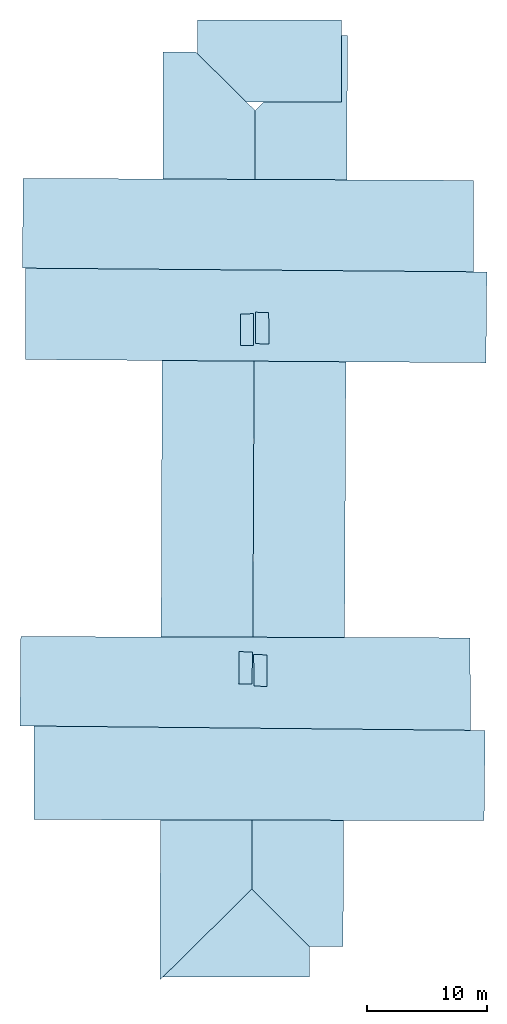
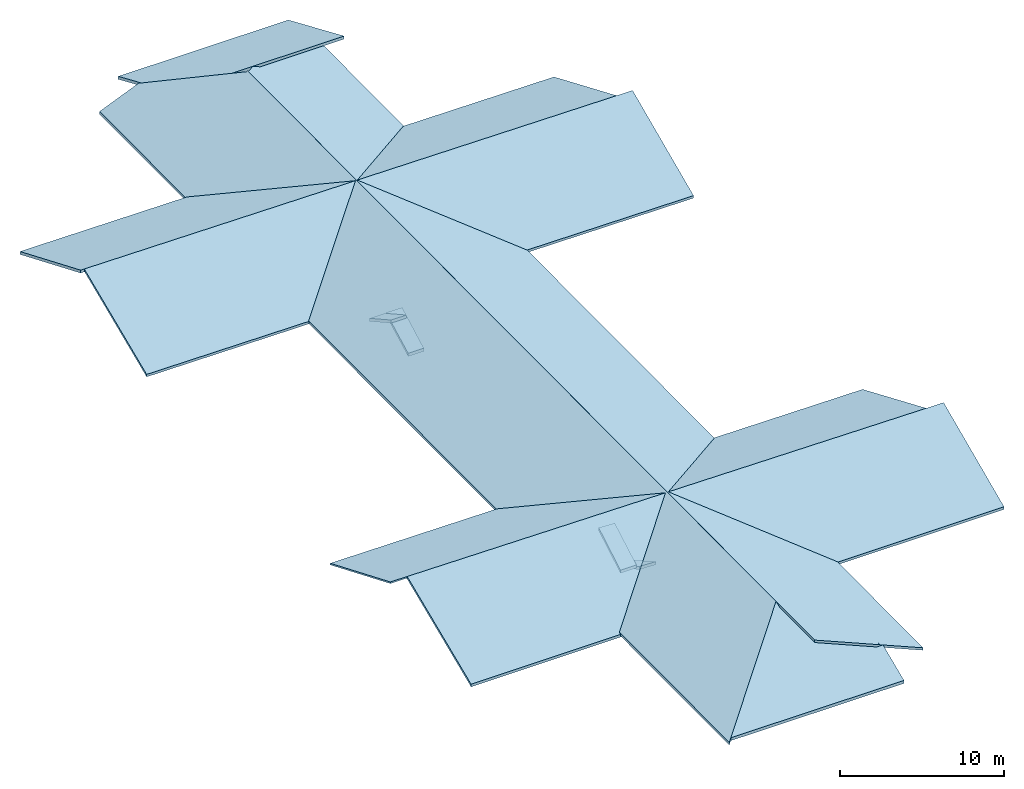
# One storey: 12 slabs, 1 element without a shape of its own.
"""IFC2X3 building model written with IfcOpenShell, lengths in metres."""

from ifc_helpers import new_model, entity, si_unit, converted_unit, derived_unit, direction, frame, origin, place, context, subcontext, project, spatial, polyline, outline, extrude, material, layer, layer_set, type_object, element, aggregate, save


model = new_model("IFC2X3")

# Units and contexts
model_context = context("Model", 3, precision=1e-05, world=origin(), true_north=direction((0.0, 1.0)))
body_context = subcontext(model_context, "Body", "Model", "MODEL_VIEW")
ifc_project = project(units=[si_unit("LENGTHUNIT", "METRE"), si_unit("AREAUNIT", "SQUARE_METRE"), si_unit("VOLUMEUNIT", "CUBIC_METRE"), converted_unit("PLANEANGLEUNIT", "DEGREE", entity("IfcRatioMeasure", 0.0174532925199433), si_unit("PLANEANGLEUNIT", "RADIAN"), dimensions=[0, 0, 0, 0, 0, 0, 0]), si_unit("MASSUNIT", "GRAM", prefix="KILO"), derived_unit("MASSDENSITYUNIT", [(si_unit("MASSUNIT", "GRAM", prefix="KILO"), 1), (si_unit("LENGTHUNIT", "METRE"), -3)]), derived_unit("MOMENTOFINERTIAUNIT", [(si_unit("LENGTHUNIT", "METRE"), 4)]), si_unit("TIMEUNIT", "SECOND"), si_unit("FREQUENCYUNIT", "HERTZ"), si_unit("THERMODYNAMICTEMPERATUREUNIT", "DEGREE_CELSIUS"), derived_unit("THERMALTRANSMITTANCEUNIT", [(si_unit("MASSUNIT", "GRAM", prefix="KILO"), 1), (si_unit("THERMODYNAMICTEMPERATUREUNIT", "KELVIN"), -1), (si_unit("TIMEUNIT", "SECOND"), -3)]), derived_unit("VOLUMETRICFLOWRATEUNIT", [(si_unit("LENGTHUNIT", "METRE"), 3), (si_unit("TIMEUNIT", "SECOND"), -1)]), si_unit("ELECTRICCURRENTUNIT", "AMPERE"), si_unit("ELECTRICVOLTAGEUNIT", "VOLT"), si_unit("POWERUNIT", "WATT"), si_unit("FORCEUNIT", "NEWTON", prefix="KILO"), si_unit("ILLUMINANCEUNIT", "LUX"), si_unit("LUMINOUSFLUXUNIT", "LUMEN"), si_unit("LUMINOUSINTENSITYUNIT", "CANDELA"), derived_unit("USERDEFINED", [(si_unit("MASSUNIT", "GRAM", prefix="KILO"), -1), (si_unit("LENGTHUNIT", "METRE"), -2), (si_unit("TIMEUNIT", "SECOND"), 3), (si_unit("LUMINOUSFLUXUNIT", "LUMEN"), 1)]), derived_unit("LINEARVELOCITYUNIT", [(si_unit("LENGTHUNIT", "METRE"), 1), (si_unit("TIMEUNIT", "SECOND"), -1)]), si_unit("PRESSUREUNIT", "PASCAL"), derived_unit("USERDEFINED", [(si_unit("LENGTHUNIT", "METRE"), -2), (si_unit("MASSUNIT", "GRAM", prefix="KILO"), 1), (si_unit("TIMEUNIT", "SECOND"), -2)]), derived_unit("LINEARFORCEUNIT", [(si_unit("MASSUNIT", "GRAM", prefix="KILO"), 1), (si_unit("LENGTHUNIT", "METRE"), 1), (si_unit("TIMEUNIT", "SECOND"), -2), (si_unit("LENGTHUNIT", "METRE"), -1)]), derived_unit("PLANARFORCEUNIT", [(si_unit("MASSUNIT", "GRAM", prefix="KILO"), 1), (si_unit("LENGTHUNIT", "METRE"), 1), (si_unit("TIMEUNIT", "SECOND"), -2), (si_unit("LENGTHUNIT", "METRE"), -2)])], contexts=[model_context])

# Site, building, storey
placement_1 = place(None, origin())
site = spatial("IfcSite", under=ifc_project, at=placement_1, CompositionType="ELEMENT")
building = spatial("IfcBuilding", under=site, at=placement_1, CompositionType="ELEMENT")
storey_placement = place(placement_1, frame((0.0, 0.0, 12.0740594863892)))
storey = spatial("IfcBuildingStorey", under=building, at=storey_placement, Name="Level 7", CompositionType="ELEMENT", Elevation=12.0740594863892)

# Roof, slabs
placement_2 = place(storey_placement, frame((7.39193296432495, 25.5369510650635, 0.0)))
roof = element("IfcRoof", 1, at=placement_2, inside=storey, Name="Roof", ObjectType="Roof", ShapeType="NOTDEFINED")
ifc_material = material(Name="Roof default")
ifc_layer_1 = layer(ifc_material, 0.217768470107194)
ifc_layer_set_1 = layer_set([ifc_layer_1], Name="Roof : 218mm")
slab_type_1 = type_object("IfcSlabType", Name="Roof : 218mm", PredefinedType="ROOF")
slab_1 = element("IfcSlab", 2, at=placement_2, type_object=slab_type_1, material=ifc_layer_set_1, Name="Roof : 218mm", ObjectType="Roof : 218mm", PredefinedType="ROOF", context=body_context, shape_type="SweptSolid", body=[
    extrude(outline(polyline([(-6.3857951637948, -3.58598383333965), (5.6142050412514, -3.58598383333965), (5.61420558800333, -0.525409985978629), (1.54317774123407, 3.84869225794582), (-6.385793206694, 3.84868539471213), (-6.3857951637948, -3.58598383333965)])), frame((-0.181047487258911, 49.685680770874, 7.41410465240479), z_axis=(-0.000154947056043607, 0.39563783301091, 0.918406598997329), x_axis=(-0.999999923308173, -0.000391642245912104, 0.0)), (0.0, -0.395637863352535, -0.918406598997329), 0.217768470107194),
])
ifc_layer_2 = layer(ifc_material, 0.119412025479108)
ifc_layer_set_2 = layer_set([ifc_layer_2], Name="Roof : 119mm")
slab_type_2 = type_object("IfcSlabType", Name="Roof : 119mm", PredefinedType="ROOF")
slab_2 = element("IfcSlab", 3, at=placement_2, type_object=slab_type_2, material=ifc_layer_set_2, Name="Roof : 119mm", ObjectType="Roof : 119mm", PredefinedType="ROOF", context=body_context, shape_type="SweptSolid", body=[
    extrude(outline(polyline([(-18.8288565602033, 4.11821929552242), (18.7692497860591, 4.11821929552242), (18.7800360802138, -3.97787922067479), (-18.7204293060697, -4.25855937037005), (-18.8288565602033, 4.11821929552242)])), frame((-1.80208086967468, -2.32204294204712, 7.59302234649658), z_axis=(0.00333846502212982, 0.389121835539899, 0.921180249330909), x_axis=(-0.999951782229567, 0.0098063456725786, -0.000518459702406836)), (0.000518459702406836, -0.389135811094586, -0.921180249330909), 0.119412025479108),
])
ifc_layer_3 = layer(ifc_material, 0.184715240861864)
ifc_layer_set_3 = layer_set([ifc_layer_3], Name="Roof : 185mm")
slab_type_3 = type_object("IfcSlabType", Name="Roof : 185mm", PredefinedType="ROOF")
slab_3 = element("IfcSlab", 4, at=placement_2, type_object=slab_type_3, material=ifc_layer_set_3, Name="Roof : 185mm", ObjectType="Roof : 185mm", PredefinedType="ROOF", context=body_context, shape_type="SweptSolid", body=[
    extrude(outline(polyline([(-19.2619894661813, 4.13158140423691), (19.2422873755232, 4.13158140423691), (19.2262536582179, -4.10914581566985), (-19.2065515675597, -4.15401699280397), (-19.2619894661813, 4.13158140423691)])), frame((-0.913518905639648, 28.3109664916992, 7.60502958297729), z_axis=(-0.00388801613831628, -0.391110430364562, 0.920335544565435), x_axis=(0.999966498948913, -0.00814996324829607, 0.000760972341273259)), (-0.000760972341273259, -0.39112901494269, -0.920335544565435), 0.184715240861864),
])
ifc_layer_4 = layer(ifc_material, 0.229266396797613)
ifc_layer_set_4 = layer_set([ifc_layer_4], Name="Roof : 229mm")
slab_type_4 = type_object("IfcSlabType", Name="Roof : 229mm", PredefinedType="ROOF")
slab_4 = element("IfcSlab", 5, at=placement_2, type_object=slab_type_4, material=ifc_layer_set_4, Name="Roof : 229mm", ObjectType="Roof : 229mm", PredefinedType="ROOF", context=body_context, shape_type="SweptSolid", body=[
    extrude(outline(polyline([(-1.51935959486812, 0.55650561620363), (1.54299250107226, 0.55650561620363), (1.53907285429364, -0.564201966580248), (-1.56270576049778, -0.548809265827012), (-1.51935959486812, 0.55650561620363)])), frame((-1.78134882450104, -1.09667873382568, 2.31131076812744), z_axis=(-0.0243790702688129, -0.488277848434215, 0.872347639224915), x_axis=(-0.00432981265470149, -0.87254717212928, -0.488510680672974)), (0.488510680672974, -0.019157737215033, -0.872347639224915), 0.229266396797613),
])
ifc_layer_5 = layer(ifc_material, 0.217144558305714)
ifc_layer_set_5 = layer_set([ifc_layer_5], Name="Roof : 217mm")
slab_type_5 = type_object("IfcSlabType", Name="Roof : 217mm", PredefinedType="ROOF")
slab_5 = element("IfcSlab", 6, at=placement_2, type_object=slab_type_5, material=ifc_layer_set_5, Name="Roof : 217mm", ObjectType="Roof : 217mm", PredefinedType="ROOF", context=body_context, shape_type="SweptSolid", body=[
    extrude(outline(polyline([(-18.8415429343464, 4.10588699379715), (18.7951549636456, 4.10588699379715), (18.8110532528547, -4.03387776003341), (-18.7646652821539, -4.17789622756088), (-18.8415429343464, 4.10588699379715)])), frame((-1.5740692615509, 35.9007530212402, 7.62140560150146), z_axis=(0.00247318675626255, 0.389447333185159, 0.921045415830423), x_axis=(-0.999966498488344, 0.00815001911061042, -0.000760979274747706)), (0.000760979274747706, -0.389454442630115, -0.921045415830423), 0.217144558305714),
])
ifc_layer_6 = layer(ifc_material, 0.195401984485415)
ifc_layer_set_6 = layer_set([ifc_layer_6], Name="Roof : 195mm")
slab_type_6 = type_object("IfcSlabType", Name="Roof : 195mm", PredefinedType="ROOF")
slab_6 = element("IfcSlab", 7, at=placement_2, type_object=slab_type_6, material=ifc_layer_set_6, Name="Roof : 195mm", ObjectType="Roof : 195mm", PredefinedType="ROOF", context=body_context, shape_type="SweptSolid", body=[
    extrude(outline(polyline([(-18.8351210278197, 4.16102427486376), (18.8032027729246, 4.16102427486376), (18.7923295407188, -4.00564113800127), (-18.7604112858236, -4.31640741172624), (-18.8351210278197, 4.16102427486376)])), frame((-0.627567291259766, -9.96059513092041, 7.57699155807495), z_axis=(-0.00429362844020268, -0.389117818894902, 0.921177989192801), x_axis=(0.999951781617494, -0.00980640790316349, 0.000518463148508191)), (-0.000518463148508191, -0.38914116133494, -0.921177989192801), 0.195401984485415),
])
ifc_layer_7 = layer(ifc_material, 0.195470123302789)
ifc_layer_set_7 = layer_set([ifc_layer_7], Name="Roof : 195mm")
slab_type_7 = type_object("IfcSlabType", Name="Roof : 195mm", PredefinedType="ROOF")
slab_7 = element("IfcSlab", 8, at=placement_2, type_object=slab_type_7, material=ifc_layer_set_7, Name="Roof : 195mm", ObjectType="Roof : 195mm", PredefinedType="ROOF", context=body_context, shape_type="SweptSolid", body=[
    extrude(outline(polyline([(-3.99167093085398, 30.4217228890451), (-1.02353694424075, 30.4217228890451), (4.37056998494758, 25.5809820882312), (4.46541899309278, -39.399775859742), (-3.82078110294563, -47.0246520065793), (-3.99167093085398, 30.4217228890451)])), frame((-5.15121760368347, 19.863486123085, 7.52554683685303), z_axis=(-0.389898208227366, 0.00141442962832144, 0.920856876289642), x_axis=(0.920839306976034, -0.0055469980373844, 0.389902810378011)), (-0.389902810378011, -0.000860302197111534, -0.920856876289642), 0.195470123302789),
])
ifc_layer_8 = layer(ifc_material, 0.229634747304557)
ifc_layer_set_8 = layer_set([ifc_layer_8], Name="Roof : 230mm")
slab_type_8 = type_object("IfcSlabType", Name="Roof : 230mm", PredefinedType="ROOF")
slab_8 = element("IfcSlab", 9, at=placement_2, type_object=slab_type_8, material=ifc_layer_set_8, Name="Roof : 230mm", ObjectType="Roof : 230mm", PredefinedType="ROOF", context=body_context, shape_type="SweptSolid", body=[
    extrude(outline(polyline([(-0.490639165654679, -1.50829935127792), (0.632500108357875, -1.50829935127792), (0.479044529665485, 1.52897332786262), (-0.620905472368681, 1.48762537469322), (-0.490639165654679, -1.50829935127792)])), frame((-0.543899655342102, -1.30667543411255, 0.751009702682495), z_axis=(0.0234513210202772, 0.490814669245308, 0.870948331415832), x_axis=(0.998808787386625, -0.0487918416151151, 0.000602022479292691)), (-0.000602022479292691, 0.49137423776136, -0.870948331415832), 0.229634747304557),
])
ifc_layer_9 = layer(ifc_material, 0.184661602017456)
ifc_layer_set_9 = layer_set([ifc_layer_9], Name="Roof : 185mm")
slab_type_9 = type_object("IfcSlabType", Name="Roof : 185mm", PredefinedType="ROOF")
slab_9 = element("IfcSlab", 10, at=placement_2, type_object=slab_type_9, material=ifc_layer_set_9, Name="Roof : 185mm", ObjectType="Roof : 185mm", PredefinedType="ROOF", context=body_context, shape_type="SweptSolid", body=[
    extrude(outline(polyline([(-22.9608196370454, -21.9356089009746), (-13.5910662224233, -21.9356089009746), (33.3484424058167, 29.6404066141122), (27.208864998759, 35.2136844924866), (-24.0054215451069, -20.9828733046497), (-22.9608196370454, -21.9356089009746)])), frame((3.24931411743164, 20.031014585495, 7.40465869903565), z_axis=(0.390495481927971, -0.00190379882303888, 0.920602875372374), x_axis=(-0.683703853162157, -0.670257912805579, 0.288623234499112)), (-0.288623234499112, 0.263034321268011, -0.920602875372374), 0.184661602017456),
])
ifc_layer_10 = layer(ifc_material, 0.228960941553307)
ifc_layer_set_10 = layer_set([ifc_layer_10], Name="Roof : 229mm")
slab_type_10 = type_object("IfcSlabType", Name="Roof : 229mm", PredefinedType="ROOF")
slab_10 = element("IfcSlab", 11, at=placement_2, type_object=slab_type_10, material=ifc_layer_set_10, Name="Roof : 229mm", ObjectType="Roof : 229mm", PredefinedType="ROOF", context=body_context, shape_type="SweptSolid", body=[
    extrude(outline(polyline([(-1.51863489812532, -0.555277141518082), (1.49173368752047, -0.555277141518082), (1.51045011871215, 0.544745421207774), (-1.48354890810731, 0.56580886182839), (-1.51863489812532, -0.555277141518082)])), frame((-0.398901343345642, 27.2704563140869, 0.74419116973877), z_axis=(-0.0129766594885699, -0.486630644253648, 0.873511432313165), x_axis=(0.0119012535715476, -0.873598106046444, -0.486502527511926)), (0.486502527511926, -0.0171278998449736, -0.873511432313165), 0.228960941553307),
])
ifc_layer_11 = layer(ifc_material, 0.228913058881483)
ifc_layer_set_11 = layer_set([ifc_layer_11], Name="Roof : 229mm")
slab_type_11 = type_object("IfcSlabType", Name="Roof : 229mm", PredefinedType="ROOF")
slab_11 = element("IfcSlab", 12, at=placement_2, type_object=slab_type_11, material=ifc_layer_set_11, Name="Roof : 229mm", ObjectType="Roof : 229mm", PredefinedType="ROOF", context=body_context, shape_type="SweptSolid", body=[
    extrude(outline(polyline([(-1.50555512599314, 0.550809919836056), (1.49504147633464, 0.550809919836056), (1.51305256774399, -0.549770718441966), (-1.50253891808549, -0.551849121230146), (-1.50555512599314, 0.550809919836056)])), frame((-1.67189478874207, 27.147928237915, 2.28672814369202), z_axis=(0.00964864493000085, 0.486379932754002, 0.873694148237944), x_axis=(-0.00265593163001865, 0.873744138280057, -0.486378583871059)), (0.486378583871059, -0.00972223879754161, -0.873694148237944), 0.228913058881483),
])
ifc_layer_12 = layer(ifc_material, 0.217474616773754)
ifc_layer_set_12 = layer_set([ifc_layer_12], Name="Roof : 217mm")
slab_type_12 = type_object("IfcSlabType", Name="Roof : 217mm", PredefinedType="ROOF")
slab_12 = element("IfcSlab", 13, at=placement_2, type_object=slab_type_12, material=ifc_layer_set_12, Name="Roof : 217mm", ObjectType="Roof : 217mm", PredefinedType="ROOF", context=body_context, shape_type="SweptSolid", body=[
    extrude(outline(polyline([(-7.96648329570008, -2.69029643176326), (4.25287060744079, -2.69029643176326), (4.25286906854388, 0.0905024506408322), (-0.539256380284591, 5.29009041288569), (-7.96648329570008, -2.69029643176326)])), frame((-0.719728082418442, -24.4211675822735, 7.15695381164551), z_axis=(-9.35359912894333e-05, -0.392744652886029, 0.919647556882772), x_axis=(0.999999971642701, -0.000238148267927335, 0.0)), (0.0, -0.392744664024285, -0.919647556882772), 0.217474616773754),
])
aggregate(roof, [slab_1, slab_2, slab_3, slab_4, slab_5, slab_6, slab_7, slab_8, slab_9, slab_10, slab_11, slab_12])

save(model, "model.ifc")
